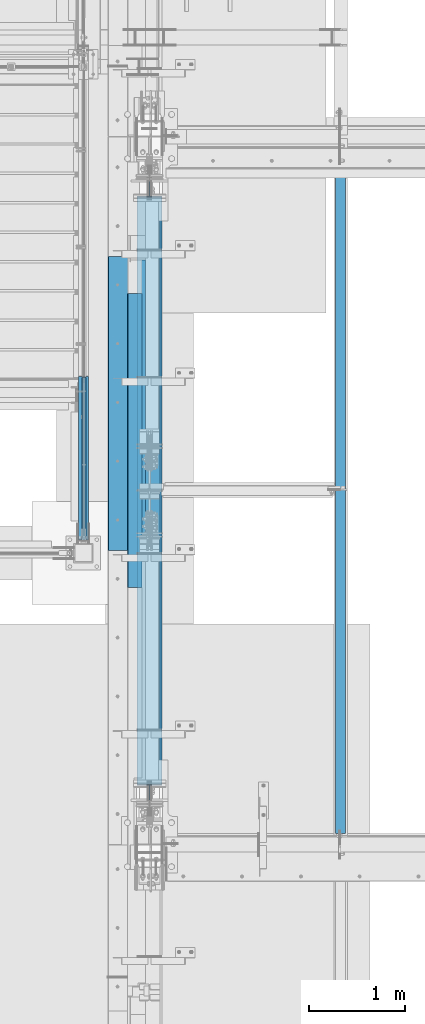
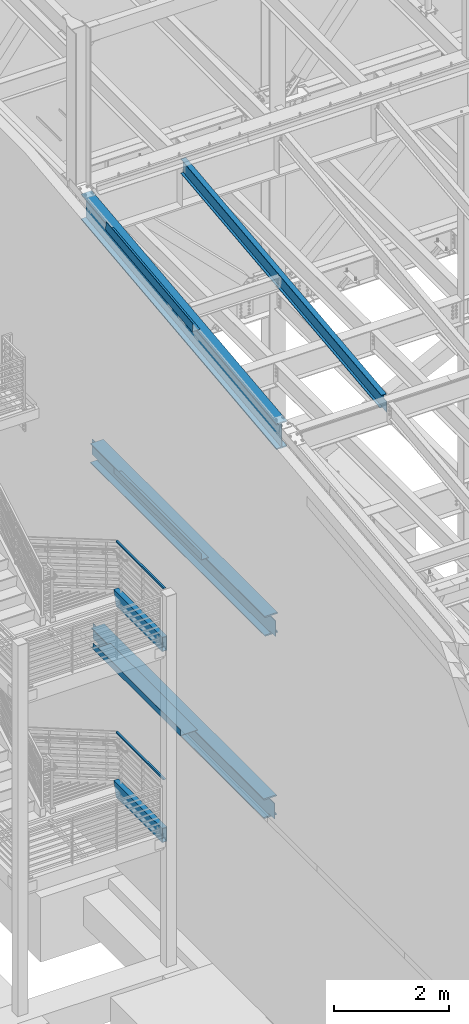
# One storey, part 730 of 1179: 9 beams, 2 members, 8 elements without a shape of their own.
"""IFC2X3 building model written with IfcOpenShell, lengths in millimetres."""

from ifc_helpers import new_model, si_unit, frame, origin_with_axes, place, context, subcontext, project, spatial, faceted_brep, material, type_object, element, aggregate, save


model = new_model("IFC2X3")

# Units and contexts
model_context = context("Model", 3, precision=1e-05, world=origin_with_axes())
body_context = subcontext(model_context, "Body", "Model", "MODEL_VIEW")
ifc_project = project(units=[si_unit("LENGTHUNIT", "METRE", prefix="MILLI"), si_unit("AREAUNIT", "SQUARE_METRE"), si_unit("VOLUMEUNIT", "CUBIC_METRE"), si_unit("MASSUNIT", "GRAM", prefix="KILO"), si_unit("TIMEUNIT", "SECOND"), si_unit("PLANEANGLEUNIT", "RADIAN"), si_unit("SOLIDANGLEUNIT", "STERADIAN"), si_unit("THERMODYNAMICTEMPERATUREUNIT", "DEGREE_CELSIUS"), si_unit("LUMINOUSINTENSITYUNIT", "LUMEN")], contexts=[model_context])

# Site, building, storey
site_placement = place(None, origin_with_axes())
site = spatial("IfcSite", under=ifc_project, at=site_placement, CompositionType="ELEMENT")
building_placement = place(site_placement, origin_with_axes())
building = spatial("IfcBuilding", under=site, at=building_placement, Name="Undefined", CompositionType="ELEMENT")
storey_placement = place(building_placement, origin_with_axes())
storey = spatial("IfcBuildingStorey", under=building, at=storey_placement, Name="Undefined", CompositionType="ELEMENT", Elevation=0.0)

# Assembly, member
assembly_1_placement = place(storey_placement, origin_with_axes())
assembly_1 = element("IfcElementAssembly", 1, at=assembly_1_placement, inside=storey, Name="GUARDRAIL", AssemblyPlace="NOTDEFINED", PredefinedType="RIGID_FRAME")
ifc_material_1 = material()
member_type = type_object("IfcMemberType", Name="HSS1-1/2X1-1/2X1/4", PredefinedType="NOTDEFINED")
member_1_placement = place(assembly_1_placement, frame((-247.650000744516, 31889.7330719655, 7258.04999816134), z_axis=(0.0, 0.0, 1.0), x_axis=(0.0, -1.0, 0.0)))
member_1 = element("IfcMember", 2, at=member_1_placement, type_object=member_type, material=ifc_material_1, Name="GUARDRAIL", ObjectType="HSS1-1/2X1-1/2X1/4", context=body_context, shape_type="Brep", body=[
    faceted_brep([(3.43796130955889, 12.69999933, -12.6999993299987), (3.43796130955889, -12.69999933, -12.6999993299987), (1651.03306073949, -12.69999933, -12.6999993292666), (1651.03306073949, 12.69999933, -12.6999993292666), (-3.43797053438539, -12.69999933, 12.6999993299987), (1676.43301577038, -12.69999933, 12.6999993307445), (-3.43797053438539, 12.69999933, 12.6999993299987), (1676.43301577038, 12.69999933, 12.6999993307445), (5.15694433551471, 19.049999235, -19.0499992349978), (-5.15695356033757, 19.049999235, 19.0499992349978), (1682.7830047681, 19.049999235, 19.0499992357472), (1644.68307174178, 19.049999235, -19.0499992342693), (-5.15695356033757, -19.049999235, 19.0499992349978), (1682.7830047681, -19.049999235, 19.0499992357472), (5.15694433551471, -19.049999235, -19.0499992349978), (1644.68307174178, -19.049999235, -19.0499992342693)], [[[0, 1, 2, 3]], [[1, 4, 5, 2]], [[4, 6, 7, 5]], [[6, 0, 3, 7]], [[8, 9, 10, 11]], [[9, 12, 13, 10]], [[12, 14, 15, 13]], [[14, 8, 11, 15]], [[13, 15, 11, 10], [5, 7, 3, 2]], [[14, 12, 9, 8], [6, 4, 1, 0]]]),
])
aggregate(assembly_1, [member_1])

assembly_2_placement = place(storey_placement, origin_with_axes())
assembly_2 = element("IfcElementAssembly", 3, at=assembly_2_placement, inside=storey, Name="GUARDRAIL", AssemblyPlace="NOTDEFINED", PredefinedType="RIGID_FRAME")
member_2_placement = place(assembly_2_placement, frame((-247.650000744516, 31884.582877441, 3184.57791779246), z_axis=(0.0, 0.0, 1.0), x_axis=(0.0, -1.0, 0.0)))
member_2 = element("IfcMember", 4, at=member_2_placement, type_object=member_type, material=ifc_material_1, Name="GUARDRAIL", ObjectType="HSS1-1/2X1-1/2X1/4", context=body_context, shape_type="Brep", body=[
    faceted_brep([(-1.7057060227562, 12.69999933, -12.6999993300001), (-1.7057060227562, -12.69999933, -12.6999993300001), (1645.88289970785, -12.69999933, -12.6999993300169), (1645.88289970785, 12.69999933, -12.6999993300169), (-8.52853495618547, -12.69999933, 12.6999993300005), (1671.28285473873, -12.69999933, 12.6999993299828), (-8.52853495618547, 12.69999933, 12.6999993300005), (1671.28285473873, 12.69999933, 12.6999993299828), (0.0, 19.0499992350015, -19.0499992349996), (-10.2342422540096, 19.049999235, 19.0499992350001), (1677.63284373645, 19.049999235, 19.0499992349824), (1639.53291071014, 19.049999235, -19.0499992350174), (-10.2342422540096, -19.049999235, 19.0499992350001), (1677.63284373645, -19.049999235, 19.0499992349824), (0.0, -19.0499992350015, -19.0499992349996), (1639.53291071014, -19.049999235, -19.0499992350174)], [[[0, 1, 2, 3]], [[1, 4, 5, 2]], [[4, 6, 7, 5]], [[6, 0, 3, 7]], [[8, 9, 10, 11]], [[9, 12, 13, 10]], [[12, 14, 15, 13]], [[14, 8, 11, 15]], [[13, 15, 11, 10], [5, 7, 3, 2]], [[14, 12, 9, 8], [6, 4, 1, 0]]]),
])
aggregate(assembly_2, [member_2])

# Assembly, beam
assembly_3_placement = place(storey_placement, origin_with_axes())
assembly_3 = element("IfcElementAssembly", 5, at=assembly_3_placement, inside=storey, Name="BEAM", AssemblyPlace="NOTDEFINED", PredefinedType="RIGID_FRAME")
ifc_material_2 = material(Name="STEEL/A36")
beam_type_1 = type_object("IfcBeamType", PredefinedType="NOTDEFINED")
beam_1_placement = place(assembly_3_placement, frame((388.937000000002, 31596.8008477536, 12820.4719325698), z_axis=(0.0, -0.993676146336441, -0.112284087038017), x_axis=(-1.0, 0.0, 0.0)))
beam_1 = element("IfcBeam", 6, at=beam_1_placement, type_object=beam_type_1, material=ifc_material_2, Name="BENT_PLATE", context=body_context, shape_type="Brep", body=[
    faceted_brep([(0.0, -3.17499999999927, -1524.0), (6.00266503170133e-10, -3.17499999922438, 1524.00000000052), (6.00266503170133e-10, 3.17500000077416, 1524.00000000052), (0.0, 3.17499999999927, -1524.0), (160.336999999976, 3.174999999379, 1523.99999999915), (160.33700000004, 3.17500000061409, -1523.99999999915), (153.98700000004, -3.17499999938263, -1523.99999999915), (153.986999999976, -3.17500000061773, 1523.99999999914), (160.337000000008, -187.325000000099, 1523.99999999907), (160.337000000008, -187.324999998866, -1523.99999999923), (153.987000000008, -187.325000000099, 1523.99999999907), (153.987000000008, -187.324999998866, -1523.99999999923)], [[[0, 1, 2, 3]], [[3, 2, 4, 5]], [[1, 0, 6, 7]], [[5, 4, 8, 9]], [[4, 2, 1, 7, 10, 8]], [[7, 6, 11, 10]], [[6, 0, 3, 5, 9, 11]], [[10, 11, 9, 8]]]),
])

assembly_4_placement = place(storey_placement, origin_with_axes())
assembly_4 = element("IfcElementAssembly", 7, at=assembly_4_placement, inside=storey, Name="STRINGER", AssemblyPlace="NOTDEFINED", PredefinedType="RIGID_FRAME")
beam_type_2 = type_object("IfcBeamType", Name="HSS12X4X3/8", PredefinedType="NOTDEFINED")
beam_2_placement = place(assembly_4_placement, frame((-253.999999980149, 30238.7000000018, 6089.64999998115), z_axis=(0.0, 0.0, 1.0), x_axis=(0.0, 1.0, 0.0)))
beam_2 = element("IfcBeam", 8, at=beam_2_placement, type_object=beam_type_2, material=ifc_material_1, Name="STRINGER", ObjectType="HSS12X4X3/8", context=body_context, shape_type="Brep", body=[
    faceted_brep([(-28.5749999926447, 41.275, -142.875), (-28.5749999926447, -41.275, -142.875), (1584.90639372461, -41.275, -142.875), (1584.90639372461, 41.275, -142.875), (-28.5749999926447, -41.275, 142.875), (1662.15866083822, -41.275, 142.875), (-28.5749999926447, 41.275, 142.875), (1662.15866083822, 41.275, 142.875), (-28.5749999926447, 50.8, -152.4), (-28.5749999926447, 50.8, 152.4), (1664.73373640867, 50.8, 152.4), (1582.33131815416, 50.8, -152.4), (-28.5749999926447, -50.8, 152.4), (1664.73373640867, -50.8, 152.4), (-28.5749999926447, -50.8, -152.4), (1582.33131815416, -50.8, -152.4)], [[[0, 1, 2, 3]], [[1, 4, 5, 2]], [[4, 6, 7, 5]], [[6, 0, 3, 7]], [[8, 9, 10, 11]], [[9, 12, 13, 10]], [[12, 14, 15, 13]], [[14, 8, 11, 15]], [[13, 15, 11, 10], [5, 7, 3, 2]], [[14, 12, 9, 8], [6, 4, 1, 0]]]),
])
aggregate(assembly_4, [beam_2])

assembly_5_placement = place(storey_placement, origin_with_axes())
assembly_5 = element("IfcElementAssembly", 9, at=assembly_5_placement, inside=storey, Name="STRINGER", AssemblyPlace="NOTDEFINED", PredefinedType="RIGID_FRAME")
beam_3_placement = place(assembly_5_placement, frame((-254.000000003771, 30200.5999999995, 2016.17791883964), z_axis=(0.0, 0.0, 1.0), x_axis=(0.0, 1.0, 0.0)))
beam_3 = element("IfcBeam", 10, at=beam_3_placement, type_object=beam_type_2, material=ifc_material_1, Name="STRINGER", ObjectType="HSS12X4X3/8", context=body_context, shape_type="Brep", body=[
    faceted_brep([(9.52499999695283, 41.275, -142.875), (9.52499999695283, -41.275, -142.875), (1623.43026812729, -41.275, -142.875), (1623.43026812729, 41.275, -142.875), (9.5249993518446, -41.2750000000001, 142.875), (1700.18709760864, -41.275, 142.875), (9.5249993518446, 41.2750000000001, 142.875), (1700.18709760864, 41.275, 142.875), (9.52499999695283, 50.8, -152.4), (9.5249993518446, 50.8, 152.4), (1702.74565859135, 50.8, 152.4), (1620.87170714458, 50.8, -152.4), (9.5249993518446, -50.8, 152.4), (1702.74565859135, -50.8, 152.4), (9.52499999695283, -50.8, -152.4), (1620.87170714458, -50.8, -152.4)], [[[0, 1, 2, 3]], [[1, 4, 5, 2]], [[4, 6, 7, 5]], [[6, 0, 3, 7]], [[8, 9, 10, 11]], [[9, 12, 13, 10]], [[12, 14, 15, 13]], [[14, 8, 11, 15]], [[13, 15, 11, 10], [5, 7, 3, 2]], [[14, 12, 9, 8], [6, 4, 1, 0]]]),
])
aggregate(assembly_5, [beam_3])

assembly_6_placement = place(storey_placement, origin_with_axes())
assembly_6 = element("IfcElementAssembly", 11, at=assembly_6_placement, inside=storey, Name="BEAM", AssemblyPlace="NOTDEFINED", PredefinedType="RIGID_FRAME")
beam_type_3 = type_object("IfcBeamType", PredefinedType="NOTDEFINED")
beam_4_placement = place(assembly_6_placement, frame((352.424987792969, 31626.175, 4105.275), z_axis=(0.0, -1.0, 0.0), x_axis=(-1.0, 0.0, 0.0)))
beam_4 = element("IfcBeam", 12, at=beam_4_placement, type_object=beam_type_3, material=ifc_material_2, Name="BENT_PLATE", context=body_context, shape_type="Brep", body=[
    faceted_brep([(0.0, -3.17499999999927, -1524.0), (6.00266503170133e-10, -3.17499999922438, 1524.00000000052), (6.00266503170133e-10, 3.17500000077416, 1524.00000000052), (0.0, 3.17499999999927, -1524.0), (352.424987792969, 3.17499999999927, 1524.0), (352.424987792969, 3.17499999999927, -1524.0), (346.074987792969, -3.17500000000109, -1524.0), (346.074987792969, -3.17500000000109, 1524.0), (352.424987792969, -130.175006103515, 1524.0), (352.424987792969, -130.175006103515, -1524.0), (346.074987792969, -130.175006103515, 1524.0), (346.074987792969, -130.175006103515, -1524.0)], [[[0, 1, 2, 3]], [[3, 2, 4, 5]], [[1, 0, 6, 7]], [[5, 4, 8, 9]], [[4, 2, 1, 7, 10, 8]], [[7, 6, 11, 10]], [[6, 0, 3, 5, 9, 11]], [[10, 11, 9, 8]]]),
])

assembly_7_placement = place(storey_placement, origin_with_axes())
assembly_7 = element("IfcElementAssembly", 13, at=assembly_7_placement, inside=storey, Name="BEAM", AssemblyPlace="NOTDEFINED", PredefinedType="RIGID_FRAME")
beam_type_4 = type_object("IfcBeamType", PredefinedType="NOTDEFINED")
beam_5_placement = place(assembly_7_placement, frame((352.425008870301, 31241.9999997295, 8016.875), z_axis=(0.0, 1.0, 0.0), x_axis=(-1.0, 0.0, 0.0)))
beam_5 = element("IfcBeam", 14, at=beam_5_placement, type_object=beam_type_4, material=ifc_material_2, Name="BENT_PLATE", context=body_context, shape_type="Brep", body=[
    faceted_brep([(0.0, -3.17499999999927, -1524.0), (6.00266503170133e-10, -3.17499999922438, 1524.00000000052), (6.00266503170133e-10, 3.17500000077416, 1524.00000000052), (0.0, 3.17499999999927, -1524.0), (142.874999594209, 3.17500001429835, 1524.00000000019), (142.874999597148, 3.17500001429835, -1523.99999999981), (149.224999857492, -3.17499998506719, -1523.9999999998), (149.224999854553, -3.17499998506719, 1524.0000000002), (142.874994388142, 130.175012106208, 1524.00000000026), (142.874994389486, 130.175012107767, -1523.99999999974), (149.224994388142, 130.17501236655, 1524.00000000027), (149.224994389486, 130.175012368109, -1523.99999999973)], [[[0, 1, 2, 3]], [[3, 2, 4, 5]], [[1, 0, 6, 7]], [[5, 4, 8, 9]], [[4, 2, 1, 7, 10, 8]], [[7, 6, 11, 10]], [[6, 0, 3, 5, 9, 11]], [[10, 11, 9, 8]]]),
])

assembly_8_placement = place(storey_placement, origin_with_axes())
assembly_8 = element("IfcElementAssembly", 15, at=assembly_8_placement, inside=storey, Name="BEAM", AssemblyPlace="NOTDEFINED", PredefinedType="RIGID_FRAME")
ifc_material_3 = material(Name="STEEL/A992")
beam_type_5 = type_object("IfcBeamType", Name="W12X22", PredefinedType="NOTDEFINED")
beam_6_placement = place(assembly_8_placement, frame((2413.0, 27068.4779321143, 12149.0171463666), z_axis=(0.0, -0.112284087038017, 0.993676146336441), x_axis=(0.0, 0.993676146336441, 0.112284087038017)))
beam_6 = element("IfcBeam", 16, at=beam_6_placement, type_object=beam_type_5, material=ifc_material_3, Name="BEAM", ObjectType="W12X22", context=body_context, shape_type="Brep", body=[
    faceted_brep([(-15.5407998117698, -3.17499999999927, -144.462499999911), (-16.7964975778959, -3.17487472700668, -155.574999999904), (135.603493906594, -3.17489667232439, -155.574999999968), (135.603493906547, -3.17499999999927, -144.462499999972), (135.603487048622, -50.7999999999993, -144.462499999972), (135.603487048618, -50.7999999999993, -155.574999999964), (7139.32426989316, 3.17499999999927, -144.462500002814), (7139.32426989316, 50.7999999999993, -144.462500002814), (135.603501703274, 50.7999999999993, -144.462499999974), (135.603494845222, 3.17489668907729, -144.462500001895), (135.603494845269, 3.17510329651486, -155.574999999966), (-16.7964975778959, 3.17512524196718, -155.574999999904), (-15.5407998117698, 3.17499999999927, -144.462499999911), (135.603501703274, 50.7999999999993, -155.574999999966), (7138.06857212703, 50.7999999999993, -155.575000002807), (7142.71544233383, 3.17499999999927, -114.451772291532), (7168.54976507951, 3.17499999999927, 114.173235457372), (7171.97241181248, 3.17499999999927, 144.462499997011), (7171.97241181248, 50.7999999999993, 144.462499997011), (7173.22810957861, 50.7999999999993, 155.574999997003), (7173.22810957861, -50.7999999999993, 155.574999997003), (7171.97241181248, -50.7999999999993, 144.462499997011), (7171.97241181248, -3.17499999999927, 144.462499997011), (7139.32426989316, -3.17499999999927, -144.462500002814), (7139.32426989316, -50.7999999999993, -144.462500002814), (7138.06857212703, -50.7999999999993, -155.575000002807), (-14.7372101429282, -3.17499999999927, -137.351003558748), (10.2521606948103, -3.17499999999927, 83.7964659398294), (10.2521606948103, 3.17499999999927, 83.7964659398294), (-14.7371967980653, 3.17499999999927, -137.350885461223), (92.2801267643408, -3.17499999999927, 74.5274145334315), (92.2801267643408, 3.17499999999927, 74.5274145334315), (97.2180202374875, -3.17499999999927, 74.9423214058406), (97.2180202374875, 3.17499999999927, 74.9423214058406), (101.621260964999, -3.17499999999927, 77.215295396114), (101.621260964999, 3.17499999999927, 77.215295396114), (104.819495461597, -3.17499999999927, 81.0002968187928), (104.819495461597, 3.17499999999927, 81.0002968187928), (106.325821517235, -3.17499999999927, 85.7210935183975), (106.325821517235, 3.17499999999927, 85.7210935183975), (112.963522565431, 3.17499999999927, 144.462499999876), (112.963522565431, 50.7999999999993, 144.462499999876), (114.219220331557, 50.7999999999993, 155.57499999987), (114.219220331557, -50.7999999999993, 155.57499999987), (112.963522565431, -50.7999999999993, 144.462499999876), (112.963522565431, -3.17499999999927, 144.462499999876)], [[[0, 1, 2, 3]], [[4, 3, 2, 5]], [[6, 7, 8, 9]], [[9, 10, 11, 12]], [[8, 13, 10, 9]], [[7, 14, 13, 8]], [[6, 15, 16, 17, 18, 19, 20, 21, 22, 23, 24, 25, 14, 7]], [[25, 24, 4, 5]], [[1, 11, 10, 13, 14, 25, 5, 2]], [[26, 27, 28, 29, 12, 11, 1, 0]], [[30, 31, 28, 27]], [[32, 33, 31, 30]], [[34, 35, 33, 32]], [[36, 37, 35, 34]], [[38, 39, 37, 36]], [[17, 16, 15, 6, 9, 12, 29, 28, 31, 33, 35, 37, 39, 40]], [[18, 17, 40, 41]], [[19, 18, 41, 42]], [[20, 19, 42, 43]], [[21, 20, 43, 44]], [[22, 21, 44, 45]], [[43, 42, 41, 40, 39, 38, 45, 44]], [[36, 34, 32, 30, 27, 26, 0, 3, 23, 22, 45, 38]], [[24, 23, 3, 4]]]),
])
aggregate(assembly_8, [beam_6])

# Beam
beam_type_6 = type_object("IfcBeamType", Name="W21X93", PredefinedType="NOTDEFINED")
beam_7_placement = place(assembly_3_placement, frame((431.800000000002, 27081.8467562485, 12030.7075801958), z_axis=(0.0, -0.112284087038017, 0.993676146336441), x_axis=(0.0, 0.993676146336441, 0.112284087038017)))
beam_7 = element("IfcBeam", 17, at=beam_7_placement, type_object=beam_type_6, material=ifc_material_3, Name="BEAM", ObjectType="W21X93", context=body_context, shape_type="Brep", body=[
    faceted_brep([(199.930151815766, -106.362499999999, -274.637499999924), (199.930151815766, 106.362499999999, -274.637499999924), (7061.63506944101, 106.362499999999, -274.637500002709), (7061.63506944101, -106.362499999999, -274.637500002709), (202.620932743182, -106.362499999999, -250.824999999939), (202.620932743182, -7.14374999999927, -250.824999999939), (214.511782852391, -7.14375000000001, -145.595003258248), (259.165541301194, -7.14375000000001, 249.575637438327), (259.306717614098, -7.14374999999927, 250.824999999757), (259.306717614098, -106.362499999999, 250.824999999757), (261.997498541514, -106.362499999999, 274.637499999742), (261.997498541514, 106.362499999999, 274.637499999742), (259.306717614098, 106.362499999999, 250.824999999757), (259.306717614098, 7.14374999999927, 250.824999999757), (202.620932743182, 7.14374999999927, -250.824999999939), (202.620932743182, 106.362499999999, -250.824999999939), (7064.32585036842, -106.362499999999, -250.825000002722), (7064.32585036842, -7.14374999999927, -250.825000002722), (7070.32680882806, -7.14375000000001, -197.718550762067), (7114.98056727682, -7.14375000000001, 197.452089934053), (7121.01163523934, -7.14374999999927, 250.824999996972), (7121.01163523934, -106.362499999999, 250.824999996972), (7123.70241616675, -106.362499999999, 274.637499996959), (7123.70241616675, 106.362499999999, 274.637499996959), (7121.01163523934, 106.362499999999, 250.824999996972), (7121.01163523934, 7.14374999999927, 250.824999996972), (7064.32585036842, 7.14374999999927, -250.825000002722), (7064.32585036842, 106.362499999999, -250.825000002722)], [[[0, 1, 2, 3]], [[0, 4, 5, 6, 7, 8, 9, 10, 11, 12, 13, 14, 15, 1]], [[5, 4, 16, 17]], [[8, 7, 6, 5, 17, 18, 19, 20]], [[9, 8, 20, 21]], [[10, 9, 21, 22]], [[11, 10, 22, 23]], [[12, 11, 23, 24]], [[13, 12, 24, 25]], [[14, 13, 25, 26]], [[15, 14, 26, 27]], [[1, 15, 27, 2]], [[26, 25, 24, 23, 22, 21, 20, 19, 18, 17, 16, 3, 2, 27]], [[4, 0, 3, 16]]]),
])

aggregate(assembly_3, [beam_1, beam_7])

beam_type_7 = type_object("IfcBeamType", Name="W16X77", PredefinedType="NOTDEFINED")
beam_8_placement = place(assembly_7_placement, frame((431.800000000001, 27051.0, 7804.15), z_axis=(0.0, 0.0, 1.0), x_axis=(0.0, 1.0, 0.0)))
beam_8 = element("IfcBeam", 18, at=beam_8_placement, type_object=beam_type_7, material=ifc_material_3, Name="BEAM", ObjectType="W16X77", context=body_context, shape_type="Brep", body=[
    faceted_brep([(624.362484940968, -130.175, 209.55), (624.362484940968, 130.175, 209.55), (613.363905768241, 130.175, 190.5), (613.363905768241, 5.55624999999998, 190.5), (613.13469653299, 5.55624999999998, 190.103), (613.13469653299, -5.55624999999998, 190.103), (613.363905768241, -5.55624999999998, 190.5), (613.363905768241, -130.175, 190.5), (656.226903411472, -5.55624999999998, 190.103), (656.226903411472, 5.55624999999998, 190.103), (670.803267608477, 5.55624999999998, 183.243356973128), (670.803267608477, -5.55624999999998, 183.243356973128), (674.659016217523, 5.55624999999998, 179.929052423035), (674.659016217523, -5.55624999999998, 179.929052423035), (676.260442692274, 5.55624999999998, 175.103407882364), (676.260442692274, -5.55624999999998, 175.103407882364), (675.151235611542, 5.55624999999998, 170.141445403769), (675.151235611542, -5.55624999999998, 170.141445403769), (671.64745310686, 5.55624999999998, 166.457029554976), (671.64745310686, -5.55624999999998, 166.457029554976), (666.747465068725, 5.55624999999998, 165.1), (666.747465068725, -5.55624999999998, 165.1), (464.138903411473, 5.55624999999998, 165.1), (464.138903411473, -5.55624999999998, 165.1), (464.138903411473, 5.55624999999998, -165.1), (464.138903411473, -5.55624999999998, -165.1), (667.091465068726, 5.55624999999998, -165.1), (667.091465068726, -5.55624999999998, -165.1), (671.991453106861, 5.55624999999998, -166.457029554975), (671.991453106861, -5.55624999999998, -166.457029554975), (675.495235611539, 5.55624999999998, -170.141445403768), (675.495235611539, -5.55624999999998, -170.141445403768), (676.604442692271, 5.55624999999998, -175.103407882363), (676.604442692271, -5.55624999999998, -175.103407882363), (675.003016217524, 5.55624999999998, -179.929052423034), (675.003016217524, -5.55624999999998, -179.929052423034), (671.147267608478, 5.55624999999998, -183.243356973128), (671.147267608478, -5.55624999999998, -183.243356973128), (656.570903411473, 5.55624999999998, -190.103), (656.570903411473, -5.55624999999998, -190.103), (624.591702180733, 5.55624999999998, -190.103), (624.591702180733, -5.55624999999998, -190.103), (6714.26719639104, 5.55624999999998, -190.5), (6714.26719639104, 130.175, -190.5), (624.362500949996, 130.175, -190.5), (624.362500949996, 5.55624999999998, -190.5), (6725.26539146808, 130.175, -209.55), (613.36430587295, 130.175, -209.55), (6725.26539146808, -130.175, -209.55), (613.36430587295, -130.175, -209.55), (6714.26719639104, -130.175, -190.5), (624.362500949996, -130.175, -190.5), (624.362500949996, -5.55624999999998, -190.5), (6714.26719639104, -5.55624999999998, -190.5), (6714.0379951603, 5.55624999999998, -190.103), (6714.0379951603, -5.55624999999998, -190.103), (6682.05879392956, 5.55624999999998, -190.103), (6682.05879392956, -5.55624999999998, -190.103), (6667.48242973255, 5.55624999999998, -183.243356973128), (6667.48242973255, -5.55624999999998, -183.243356973128), (6663.6266811235, 5.55624999999998, -179.929052423035), (6663.6266811235, -5.55624999999998, -179.929052423035), (6662.02525464876, 5.55624999999998, -175.103407882363), (6662.02525464876, -5.55624999999998, -175.103407882363), (6663.13446172949, 5.55624999999998, -170.141445403768), (6663.13446172949, -5.55624999999998, -170.141445403768), (6666.63824423417, 5.55624999999998, -166.457029554975), (6666.63824423417, -5.55624999999998, -166.457029554975), (6671.5382322723, 5.55624999999998, -165.1), (6671.5382322723, -5.55624999999998, -165.1), (6874.49079392956, 5.55624999999998, -165.1), (6874.49079392956, -5.55624999999998, -165.1), (6874.49079392956, -5.55624999999998, 165.1), (6874.49079392956, 5.55624999999998, 165.1), (6671.88223227231, 5.55624999999998, 165.1), (6671.88223227231, -5.55624999999998, 165.1), (6666.98224423417, 5.55624999999998, 166.457029554975), (6666.98224423417, -5.55624999999998, 166.457029554975), (6663.47846172949, 5.55624999999998, 170.141445403767), (6663.47846172949, -5.55624999999998, 170.141445403767), (6662.36925464876, 5.55624999999998, 175.103407882362), (6662.36925464876, -5.55624999999998, 175.103407882362), (6663.97068112351, 5.55624999999998, 179.929052423034), (6663.97068112351, -5.55624999999998, 179.929052423034), (6667.82642973255, 5.55624999999998, 183.243356973128), (6667.82642973255, -5.55624999999998, 183.243356973128), (6682.40279392956, 5.55624999999998, 190.103), (6682.40279392956, -5.55624999999998, 190.103), (6725.49500080804, 5.55624999999998, 190.103), (6725.49500080804, -5.55624999999998, 190.103), (6725.26579157278, -130.175, 190.5), (6725.26579157278, -5.55624999999998, 190.5), (6725.26579157278, 5.55624999999998, 190.5), (6725.26579157278, 130.175, 190.5), (6714.26721240007, 130.175, 209.55), (6714.26721240007, -130.175, 209.55)], [[[0, 1, 2, 3, 4, 5, 6, 7]], [[8, 9, 10, 11]], [[11, 10, 12, 13]], [[13, 12, 14, 15]], [[15, 14, 16, 17]], [[17, 16, 18, 19]], [[19, 18, 20, 21]], [[21, 20, 22, 23]], [[23, 22, 24, 25]], [[26, 27, 25, 24]], [[27, 26, 28, 29]], [[29, 28, 30, 31]], [[31, 30, 32, 33]], [[33, 32, 34, 35]], [[35, 34, 36, 37]], [[37, 36, 38, 39]], [[39, 38, 40, 41]], [[42, 43, 44, 45]], [[43, 46, 47, 44]], [[46, 48, 49, 47]], [[48, 50, 51, 49]], [[41, 40, 45, 44, 47, 49, 51, 52]], [[50, 53, 52, 51]], [[48, 46, 43, 42, 54, 55, 53, 50]], [[56, 57, 55, 54]], [[57, 56, 58, 59]], [[59, 58, 60, 61]], [[61, 60, 62, 63]], [[63, 62, 64, 65]], [[65, 64, 66, 67]], [[67, 66, 68, 69]], [[69, 68, 70, 71]], [[72, 71, 70, 73]], [[74, 75, 72, 73]], [[75, 74, 76, 77]], [[77, 76, 78, 79]], [[79, 78, 80, 81]], [[81, 80, 82, 83]], [[83, 82, 84, 85]], [[85, 84, 86, 87]], [[87, 86, 88, 89]], [[90, 91, 89, 88, 92, 93, 94, 95]], [[90, 95, 0, 7]], [[91, 90, 7, 6]], [[8, 11, 13, 15, 17, 19, 21, 23, 25, 27, 29, 31, 33, 35, 37, 39, 41, 52, 53, 55, 57, 59, 61, 63, 65, 67, 69, 71, 72, 75, 77, 79, 81, 83, 85, 87, 89, 91, 6, 5]], [[9, 8, 5, 4]], [[92, 88, 86, 84, 82, 80, 78, 76, 74, 73, 70, 68, 66, 64, 62, 60, 58, 56, 54, 42, 45, 40, 38, 36, 34, 32, 30, 28, 26, 24, 22, 20, 18, 16, 14, 12, 10, 9, 4, 3]], [[93, 92, 3, 2]], [[94, 93, 2, 1]], [[95, 94, 1, 0]]]),
])

aggregate(assembly_7, [beam_5, beam_8])

beam_9_placement = place(assembly_6_placement, frame((431.800000000002, 27538.5830010662, 3892.55), z_axis=(0.0, 0.0, 1.0), x_axis=(0.0, 1.0, 0.0)))
beam_9 = element("IfcBeam", 19, at=beam_9_placement, type_object=beam_type_7, material=ifc_material_3, Name="BEAM", ObjectType="W16X77", context=body_context, shape_type="Brep", body=[
    faceted_brep([(6203.50899544609, -130.175, 190.5), (6203.50899544609, -5.55624999999998, 190.5), (6203.73820468135, -5.55624999999998, 190.103), (6203.73820468135, 5.55624999999998, 190.103), (6203.50899544609, 5.55624999999998, 190.5), (6203.50899544609, 130.175, 190.5), (6192.51041627337, 130.175, 209.55), (6192.51041627337, -130.175, 209.55), (172.923597538524, -130.174999999999, -190.5), (161.925402461478, -130.174999999999, -209.55), (6203.50859534139, -130.175, -209.55), (6192.51040026435, -130.175, -190.5), (161.925402461478, 130.174999999999, -209.55), (6203.50859534139, 130.175, -209.55), (172.923597538524, 130.174999999999, -190.5), (6192.51040026435, 130.175, -190.5), (172.923597538524, 5.55625000000146, -190.5), (6192.51040026435, 5.55624999999998, -190.5), (6146.06963360586, -5.55624999999998, 183.243356973127), (6146.06963360586, 5.55624999999998, 183.243356973127), (6160.64599780287, 5.55624999999998, 190.103), (6160.64599780287, -5.55624999999998, 190.103), (6142.21388499682, -5.55624999999998, 179.929052423034), (6142.21388499682, 5.55624999999998, 179.929052423034), (6140.61245852207, -5.55624999999998, 175.103407882362), (6140.61245852207, 5.55624999999998, 175.103407882362), (6141.7216656028, -5.55624999999998, 170.141445403767), (6141.7216656028, 5.55624999999998, 170.141445403767), (6145.22544810748, -5.55624999999998, 166.457029554975), (6145.22544810748, 5.55624999999998, 166.457029554975), (6150.12543614562, -5.55624999999998, 165.1), (6150.12543614562, 5.55624999999998, 165.1), (6352.73399780287, -5.55624999999998, 165.1), (6352.73399780287, 5.55624999999998, 165.1), (6352.73399780287, -5.55624999999998, -165.1), (6352.73399780287, 5.55624999999998, -165.1), (6149.78143614561, -5.55624999999998, -165.1), (6149.78143614561, 5.55624999999998, -165.1), (6144.88144810748, -5.55624999999998, -166.457029554975), (6144.88144810748, 5.55624999999998, -166.457029554975), (6141.3776656028, -5.55624999999998, -170.141445403767), (6141.3776656028, 5.55624999999998, -170.141445403767), (6140.26845852206, -5.55624999999998, -175.103407882363), (6140.26845852206, 5.55624999999998, -175.103407882363), (6141.86988499681, -5.55624999999998, -179.929052423034), (6141.86988499681, 5.55624999999998, -179.929052423034), (6145.72563360586, -5.55624999999998, -183.243356973128), (6145.72563360586, 5.55624999999998, -183.243356973128), (6160.30199780287, -5.55624999999998, -190.103), (6160.30199780287, 5.55624999999998, -190.103), (6192.28119903361, -5.55624999999998, -190.103), (6192.28119903361, 5.55624999999998, -190.103), (6192.51040026435, -5.55624999999998, -190.5), (172.923597538524, -5.55625000000146, -190.5), (173.152798769261, -5.55625000000146, -190.103), (173.152798769261, 5.55625000000146, -190.103), (205.132000000001, -5.55625000000146, -190.103), (205.132000000001, 5.55625000000146, -190.103), (219.708364197006, -5.55625000000146, -183.243356973128), (219.708364197006, 5.55625000000146, -183.243356973128), (223.564112806052, -5.55625000000146, -179.929052423034), (223.564112806052, 5.55625000000146, -179.929052423034), (225.165539280799, -5.55625000000146, -175.103407882363), (225.165539280799, 5.55625000000146, -175.103407882363), (224.056332200067, -5.55625000000146, -170.141445403768), (224.056332200067, 5.55625000000146, -170.141445403768), (220.552549695389, -5.55625000000146, -166.457029554975), (220.552549695389, 5.55625000000146, -166.457029554975), (215.652561657254, -5.55625000000146, -165.1), (215.652561657254, 5.55625000000146, -165.1), (12.7000000000007, -5.55625000000146, -165.1), (12.7000000000007, 5.55625000000146, -165.1), (12.7000000000007, -5.55625000000146, 165.1), (12.7000000000007, 5.55625000000146, 165.1), (215.308561657253, -5.55625000000146, 165.1), (215.308561657253, 5.55625000000146, 165.1), (220.208549695388, -5.55625000000146, 166.457029554976), (220.208549695388, 5.55625000000146, 166.457029554976), (223.71233220007, -5.55625000000146, 170.141445403769), (223.71233220007, 5.55625000000146, 170.141445403769), (224.821539280802, -5.55625000000146, 175.103407882364), (224.821539280802, 5.55625000000146, 175.103407882364), (223.220112806051, -5.55625000000146, 179.929052423035), (223.220112806051, 5.55625000000146, 179.929052423035), (219.364364197005, -5.55625000000146, 183.243356973128), (219.364364197005, 5.55625000000146, 183.243356973128), (204.788, -5.55625000000146, 190.103), (204.788, 5.55625000000146, 190.103), (161.695793121518, -5.55625000000146, 190.103), (161.695793121518, 5.55625000000146, 190.103), (172.923581529496, -130.174999999999, 209.55), (172.923581529496, 130.174999999999, 209.55), (161.925002356769, 130.174999999999, 190.5), (161.925002356769, 5.55625000000146, 190.5), (161.925002356769, -5.55625000000146, 190.5), (161.925002356769, -130.174999999999, 190.5)], [[[0, 1, 2, 3, 4, 5, 6, 7]], [[8, 9, 10, 11]], [[9, 12, 13, 10]], [[12, 14, 15, 13]], [[14, 16, 17, 15]], [[18, 19, 20, 21]], [[22, 23, 19, 18]], [[24, 25, 23, 22]], [[26, 27, 25, 24]], [[28, 29, 27, 26]], [[30, 31, 29, 28]], [[31, 30, 32, 33]], [[32, 34, 35, 33]], [[36, 37, 35, 34]], [[38, 39, 37, 36]], [[40, 41, 39, 38]], [[42, 43, 41, 40]], [[44, 45, 43, 42]], [[46, 47, 45, 44]], [[48, 49, 47, 46]], [[49, 48, 50, 51]], [[10, 13, 15, 17, 51, 50, 52, 11]], [[53, 8, 11, 52]], [[54, 55, 16, 14, 12, 9, 8, 53]], [[56, 57, 55, 54]], [[58, 59, 57, 56]], [[60, 61, 59, 58]], [[62, 63, 61, 60]], [[64, 65, 63, 62]], [[66, 67, 65, 64]], [[68, 69, 67, 66]], [[69, 68, 70, 71]], [[72, 73, 71, 70]], [[74, 75, 73, 72]], [[76, 77, 75, 74]], [[78, 79, 77, 76]], [[80, 81, 79, 78]], [[82, 83, 81, 80]], [[84, 85, 83, 82]], [[86, 87, 85, 84]], [[87, 86, 88, 89]], [[90, 91, 92, 93, 89, 88, 94, 95]], [[90, 95, 0, 7]], [[91, 90, 7, 6]], [[92, 91, 6, 5]], [[93, 92, 5, 4]], [[20, 19, 23, 25, 27, 29, 31, 33, 35, 37, 39, 41, 43, 45, 47, 49, 51, 17, 16, 55, 57, 59, 61, 63, 65, 67, 69, 71, 73, 75, 77, 79, 81, 83, 85, 87, 89, 93, 4, 3]], [[21, 20, 3, 2]], [[94, 88, 86, 84, 82, 80, 78, 76, 74, 72, 70, 68, 66, 64, 62, 60, 58, 56, 54, 53, 52, 50, 48, 46, 44, 42, 40, 38, 36, 34, 32, 30, 28, 26, 24, 22, 18, 21, 2, 1]], [[95, 94, 1, 0]]]),
])

aggregate(assembly_6, [beam_4, beam_9])

save(model, "model.ifc")
